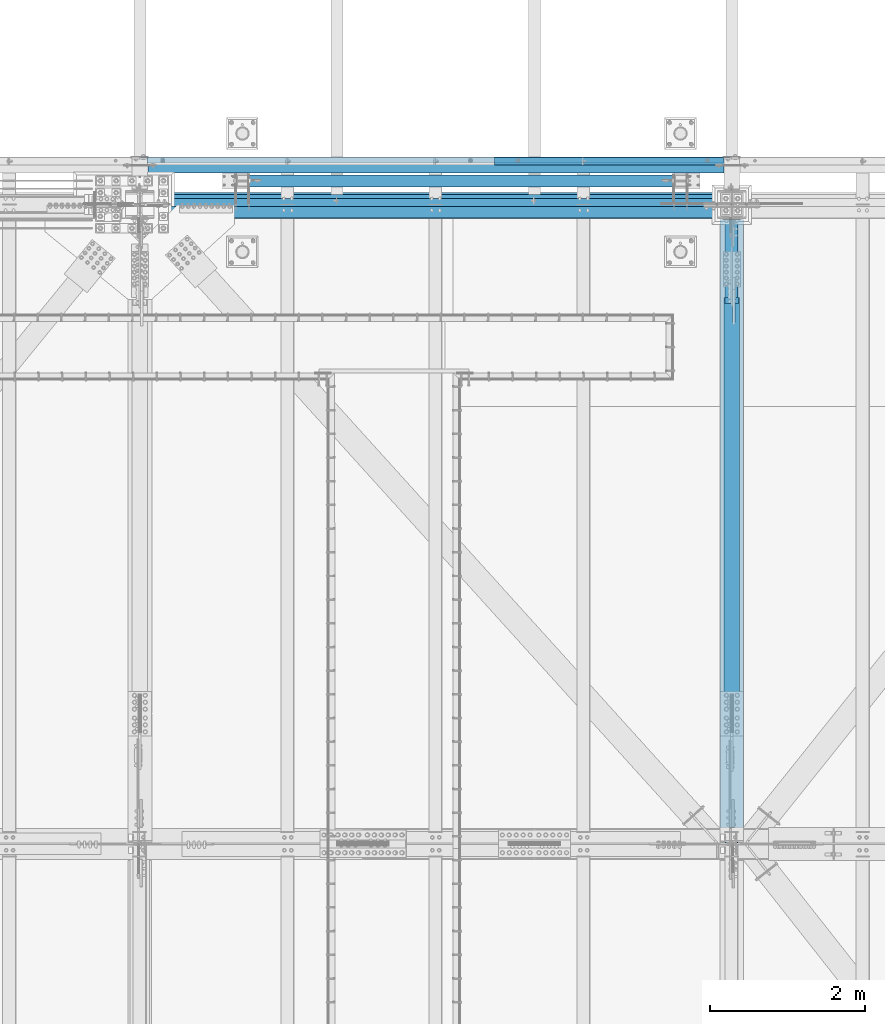
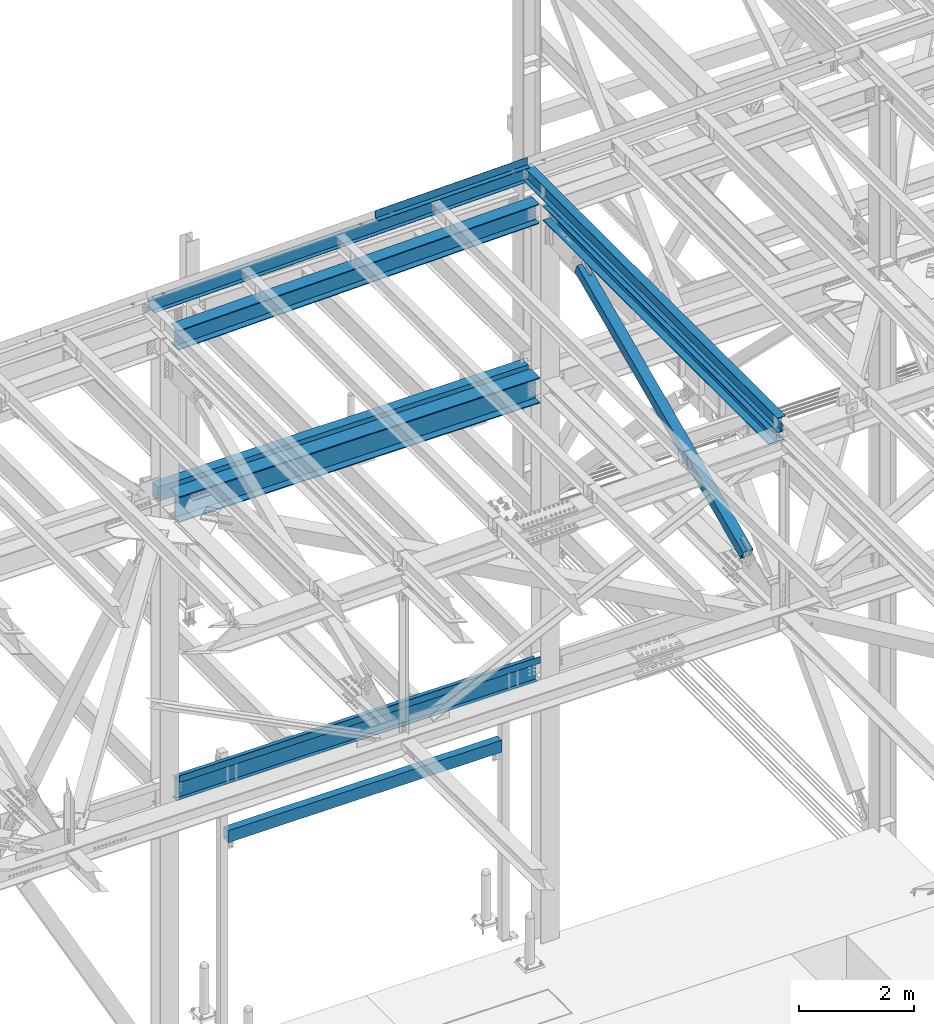
# One storey, part 1928 of 3843: 10 beams, 1 member, 9 elements without a shape of their own.
"""IFC2X3 building model written with IfcOpenShell, lengths in millimetres."""

from ifc_helpers import new_model, si_unit, frame, origin_with_axes, place, context, subcontext, project, spatial, faceted_brep, material, type_object, element, aggregate, save


model = new_model("IFC2X3")

# Units and contexts
model_context = context("Model", 3, precision=1e-05, world=origin_with_axes())
body_context = subcontext(model_context, "Body", "Model", "MODEL_VIEW")
ifc_project = project(units=[si_unit("LENGTHUNIT", "METRE", prefix="MILLI"), si_unit("AREAUNIT", "SQUARE_METRE"), si_unit("VOLUMEUNIT", "CUBIC_METRE"), si_unit("MASSUNIT", "GRAM", prefix="KILO"), si_unit("TIMEUNIT", "SECOND"), si_unit("PLANEANGLEUNIT", "RADIAN"), si_unit("SOLIDANGLEUNIT", "STERADIAN"), si_unit("THERMODYNAMICTEMPERATUREUNIT", "DEGREE_CELSIUS"), si_unit("LUMINOUSINTENSITYUNIT", "LUMEN")], contexts=[model_context])

# Site, building, storey
site_placement = place(None, origin_with_axes())
site = spatial("IfcSite", under=ifc_project, at=site_placement, CompositionType="ELEMENT")
building_placement = place(site_placement, origin_with_axes())
building = spatial("IfcBuilding", under=site, at=building_placement, Name="Undefined", CompositionType="ELEMENT")
storey_placement = place(building_placement, origin_with_axes())
storey = spatial("IfcBuildingStorey", under=building, at=storey_placement, Name="Undefined", CompositionType="ELEMENT", Elevation=0.0)

# Assembly, beam
assembly_1_placement = place(storey_placement, origin_with_axes())
assembly_1 = element("IfcElementAssembly", 1, at=assembly_1_placement, inside=storey, Name="CHANNEL", AssemblyPlace="NOTDEFINED", PredefinedType="RIGID_FRAME")
ifc_material_1 = material(Name="STEEL/A572-50")
beam_type_1 = type_object("IfcBeamType", Name="C12X20.7", PredefinedType="NOTDEFINED")
beam_1_placement = place(assembly_1_placement, frame((62633.0420977104, 92786.1999979518, 46128.444972132), z_axis=(-0.0211520980073474, 0.0, 0.999776269347241), x_axis=(0.999776270257024, 0.0, 0.0211520550054619)))
beam_1 = element("IfcBeam", 2, at=beam_1_placement, type_object=beam_type_1, material=ifc_material_1, Name="CHANNEL", ObjectType="C12X20.7", context=body_context, shape_type="Brep", body=[
    faceted_brep([(15.8752464537756, 30.1625000000058, -126.999999939733), (15.8750003662499, 38.1000000000058, -127.000000023749), (85.725000532555, 38.1000000000058, -127.000000023691), (85.725000532555, 30.1625000000058, -127.000000023691), (90.5850800505723, 38.1000000000058, -127.966729946267), (90.5850800505723, 30.1625000000058, -127.966729946267), (94.7052565187187, 38.1000000000058, -130.719743846734), (94.7052565187187, 30.1625000000058, -130.719743846734), (97.4582704191853, 38.1000000000058, -134.839920314858), (97.458270419178, 30.1625000000058, -134.674927499669), (98.4250003417692, 1.00112811196595e-06, -139.699999832876), (98.4250003417692, 38.1000000000058, -139.699999832876), (98.4250003417837, 38.1000000000058, -152.399999999638), (98.4250003417837, -38.1000000000058, -152.399999999638), (98.4250003417765, -38.1000000000058, -146.047459999652), (7523.28318920102, -38.1000000000058, 146.047460007321), (7523.28318920101, -38.1000000000058, 152.400000007307), (98.4250003414782, -38.1000000000058, 152.399999999863), (98.4250003414927, -38.1000000000058, 146.047459999871), (7523.28318920101, 38.1000000000058, 152.400000007307), (98.4250003414782, 38.1000000000058, 152.399999999863), (85.7250005323076, 30.1625000000058, 126.99999997508), (85.7250005323076, 38.1000000000058, 126.99999997508), (15.8750006201954, 38.1000000000058, 126.999999975014), (15.8752517919565, 30.1625000000058, 127.000000059044), (90.5850800503176, 30.1625000000058, 127.966729897671), (90.5850800503176, 38.1000000000058, 127.966729897671), (94.7052565184495, 30.1625000000058, 130.719743798138), (94.7052565184495, 38.1000000000058, 130.719743798138), (97.4582704189161, 30.1625000000058, 134.674927499887), (97.4582704189233, 38.1000000000058, 134.839920266269), (98.4250003414927, 1.29402906168252e-06, 139.699999784301), (98.4250003414927, 38.1000000000058, 139.699999784301), (7524.24991912362, 30.1625000000058, 134.674927507331), (7523.28318920104, 2.4073087843135e-06, 139.699999606266), (7523.28318920104, 38.1000000000058, 139.699999606266), (7524.24991912362, 38.1000000000058, 134.839920088249), (7527.00293302412, 30.1625000000058, 130.719743620124), (7527.00293302412, 38.1000000000058, 130.719743620124), (7531.12310949228, 30.1625000000058, 127.966729719657), (7531.12310949228, 38.1000000000058, 127.966729719657), (7535.98318901036, 30.1625000000058, 126.999999797081), (7535.98318901036, 38.1000000000058, 126.999999797081), (7605.83053466881, 30.1625000000058, 126.999999797132), (7605.83022600554, 38.1000000000058, 126.999999797139), (7605.83053421144, 30.1625000000058, 114.299999001392), (7605.83052590682, 30.1625000000058, -116.300000996322), (7605.83052552149, 30.1625000000058, -127.000000201639), (7605.83021685822, 38.1000000000058, -127.000000201639), (7535.98318901064, 30.1625000000058, -127.000000201682), (7535.98318901064, 38.1000000000058, -127.000000201682), (7531.12310949257, 30.1625000000058, -127.966730124273), (7531.12310949257, 38.1000000000058, -127.966730124273), (7527.00293302441, 30.1625000000058, -130.71974402474), (7527.00293302441, 38.1000000000058, -130.71974402474), (7524.24991912393, 30.1625000000058, -134.674927492233), (7524.24991912393, 38.1000000000058, -134.839920492872), (7523.28318920133, -1.12078851088881e-07, -139.700000010889), (7523.28318920133, 38.1000000000058, -139.700000010889), (7523.28318920134, -38.1000000000058, -146.047459992216), (7523.28318920134, -38.1000000000058, -152.399999992194), (7523.28318920134, 38.1000000000058, -152.399999992194), (15.8752466786536, 30.1625000000058, -116.299999310024), (15.8752515250453, 30.1625000000058, 114.300000683208)], [[[0, 1, 2, 3]], [[3, 2, 4, 5]], [[5, 4, 6, 7]], [[7, 6, 8, 9]], [[10, 11, 12, 13, 14]], [[9, 8, 11, 10]], [[15, 16, 17, 18]], [[16, 19, 20, 17]], [[21, 22, 23, 24]], [[25, 26, 22, 21]], [[27, 28, 26, 25]], [[29, 30, 28, 27]], [[31, 32, 30, 29]], [[17, 20, 32, 31, 18]], [[29, 33, 34, 15, 18, 31]], [[16, 15, 34, 35, 19]], [[33, 36, 35, 34]], [[37, 38, 36, 33]], [[39, 40, 38, 37]], [[41, 42, 40, 39]], [[43, 44, 42, 41]], [[44, 43, 45, 46, 47, 48]], [[47, 49, 50, 48]], [[51, 52, 50, 49]], [[53, 54, 52, 51]], [[55, 56, 54, 53]], [[57, 58, 56, 55]], [[59, 60, 61, 58, 57]], [[60, 59, 14, 13]], [[61, 60, 13, 12]], [[6, 4, 2, 1, 23, 22, 26, 28, 30, 32, 20, 19, 35, 36, 38, 40, 42, 44, 48, 50, 52, 54, 56, 58, 61, 12, 11, 8]], [[62, 63, 24, 23, 1, 0]], [[55, 53, 51, 49, 47, 46, 45, 43, 41, 39, 37, 33, 29, 27, 25, 21, 24, 63, 62, 0, 3, 5, 7, 9]], [[59, 57, 55, 9, 10, 14]]]),
])

assembly_2_placement = place(storey_placement, origin_with_axes())
assembly_2 = element("IfcElementAssembly", 3, at=assembly_2_placement, inside=storey, Name="BEAM", AssemblyPlace="NOTDEFINED", PredefinedType="RIGID_FRAME")
ifc_material_2 = material(Name="STEEL/A992")
beam_type_2 = type_object("IfcBeamType", Name="W12X26", PredefinedType="NOTDEFINED")
beam_2_placement = place(assembly_2_placement, frame((70253.1092623905, 83985.3859476717, 46302.7356375803), z_axis=(-0.0211520977514592, 0.00183800499970675, 0.999774579842043), x_axis=(0.0, 0.999998310110039, -0.00183841700020231)))
beam_2 = element("IfcBeam", 4, at=beam_2_placement, type_object=beam_type_2, material=ifc_material_2, Name="BEAM", ObjectType="W12X26", context=body_context, shape_type="Brep", body=[
    faceted_brep([(12.7032316026452, 82.5500000008906, -155.575000000761), (12.6857245687861, 82.550000000876, -146.050000000731), (8839.2149373373, 82.5500000014727, -146.050000029354), (8839.21493733734, 82.5500000015018, -155.575000029385), (12.6826379569102, 3.17500000042492, -146.050000000549), (8839.2149373368, 3.1750000010361, -146.050000029165), (12.1457555855741, 3.17499999961001, 146.050000000469), (8839.21493733574, 3.17500000022119, 146.049999971852), (12.14884219745, 82.550000000032, 146.050000000294), (8839.21493733625, 82.5500000006432, 146.049999971663), (12.1313351636054, 82.5500000000175, 155.575000000317), (8839.2149373362, 82.5500000006141, 155.574999971701), (12.124915010907, -82.5500000009051, 155.575000000703), (8839.21493733513, -82.5500000002939, 155.574999972079), (12.1424220447516, -82.5500000008615, 146.050000000665), (8839.21493733516, -82.5500000002503, 146.049999972041), (12.1455086566275, -3.17500000042492, 146.050000000483), (8839.21493733568, -3.17499999982829, 146.049999971867), (12.6823910279636, -3.17499999959546, -146.050000000534), (8839.21493733674, -3.17499999898428, -146.05000002915), (12.6793044160877, -82.550000000032, -146.050000000352), (8839.21493733623, -82.5499999994354, -146.050000028976), (12.6968114499323, -82.5500000000175, -155.57500000039), (8839.21493733626, -82.5499999994063, -155.575000029006)], [[[0, 1, 2, 3]], [[1, 4, 5, 2]], [[4, 6, 7, 5]], [[6, 8, 9, 7]], [[8, 10, 11, 9]], [[10, 12, 13, 11]], [[12, 14, 15, 13]], [[14, 16, 17, 15]], [[16, 18, 19, 17]], [[18, 20, 21, 19]], [[20, 22, 23, 21]], [[22, 0, 3, 23]], [[5, 7, 9, 11, 13, 15, 17, 19, 21, 23, 3, 2]], [[22, 20, 18, 16, 14, 12, 10, 8, 6, 4, 1, 0]]]),
])
aggregate(assembly_2, [beam_2])

# Beam
ifc_material_3 = material(Name="STEEL/A36")
beam_type_3 = type_object("IfcBeamType", PredefinedType="NOTDEFINED")
beam_3_placement = place(assembly_1_placement, frame((68725.1813147348, 92722.6999708297, 46412.9451497034), z_axis=(0.999776270257024, 0.0, 0.0211520550054619), x_axis=(0.0, 1.0, 0.0)))
beam_3 = element("IfcBeam", 5, at=beam_3_placement, type_object=beam_type_3, material=ifc_material_3, Name="BENT_PLATE", context=body_context, shape_type="Brep", body=[
    faceted_brep([(-5.28234522789717e-09, 1.04169885162264e-07, -1524.79400000861), (-6.66477717459202e-09, 3.17499999871507, -1521.61900009272), (95.2499987022602, 3.17500004013709, -1521.61900009349), (98.4249986312061, 1.46974343806505e-07, -1524.79400000939), (95.2499986384064, 161.925001341384, -1521.61900009353), (98.4249985660863, 161.925001342694, -1524.79400000979), (95.2499987169431, 3.17500004271278, 1524.79400000787), (95.2499986491457, 161.925001348034, 1524.79400000749), (-3.91446519643068e-09, -3.17500000128348, -1524.79400000861), (6.66477717459202e-09, -3.17499999869324, 1524.79400000864), (3.91446519643068e-09, 3.17500000129803, 1524.79400000864), (101.599998704885, -3.17499995710386, -1524.79400000941), (101.599998719568, -3.17499995451362, 1524.79400000782), (101.599998649152, 161.925001350661, 1524.79400000744), (101.599998638398, 161.925001344003, -1524.7940000098)], [[[0, 1, 2, 3]], [[3, 2, 4, 5]], [[6, 7, 4, 2]], [[8, 9, 10, 1, 0]], [[10, 6, 2, 1]], [[9, 8, 11, 12]], [[6, 10, 9, 12, 13, 7]], [[12, 11, 14, 13]], [[14, 11, 8, 0, 3, 5]], [[7, 13, 14, 5, 4]]]),
])

aggregate(assembly_1, [beam_1, beam_3])

# Assembly, beam
assembly_3_placement = place(storey_placement, origin_with_axes())
assembly_3 = element("IfcElementAssembly", 6, at=assembly_3_placement, inside=storey, Name="BEAM", AssemblyPlace="NOTDEFINED", PredefinedType="RIGID_FRAME")
beam_type_4 = type_object("IfcBeamType", Name="W21X101", PredefinedType="NOTDEFINED")
beam_4_placement = place(assembly_3_placement, frame((62636.4, 92214.7, 42197.3375), z_axis=(0.0, 0.0, 1.0), x_axis=(1.0, 0.0, 0.0)))
beam_4 = element("IfcBeam", 7, at=beam_4_placement, type_object=beam_type_4, material=ifc_material_2, Name="BEAM", ObjectType="W21X101", context=body_context, shape_type="Brep", body=[
    faceted_brep([(7423.14999999999, 6.34999999999854, -250.824999999997), (7423.14999999999, 155.575000000001, -250.824999999997), (196.850000000006, 155.575000000001, -250.824999999997), (196.850000000006, 6.34999999999854, -250.824999999997), (7423.14999999999, -155.575000000001, -271.462500000001), (7423.14999999999, -155.575000000001, -250.824999999997), (196.850000000006, -155.575000000001, -250.824999999997), (196.850000000006, -155.575000000001, -271.462500000001), (7423.14999999999, 155.575000000001, -271.462500000001), (196.850000000006, 155.575000000001, -271.462500000001), (7423.14999999999, 6.34999999999854, 250.824999999997), (7423.14999999999, 155.575000000001, 250.824999999997), (7423.14999999999, 155.575000000001, 271.462500000001), (7423.14999999999, -155.575000000001, 271.462500000001), (7423.14999999999, -155.575000000001, 250.824999999997), (7423.14999999999, -6.34999999999854, 250.824999999997), (7423.14999999999, -6.34999999999854, -250.824999999997), (193.675000000003, 6.35000000000036, 250.428), (193.675000000003, -6.35000000000036, 250.428), (193.675000000003, -6.35000000000036, 250.824999999997), (193.675000000003, 6.35000000000036, 250.824999999997), (228.60000000002, 6.35000000000036, 250.428), (228.60000000002, -6.35000000000036, 250.428), (273.984905435093, 6.35000000000036, 234.406795689014), (273.984905435093, -6.35000000000036, 234.406795689014), (278.274267898814, 6.35000000000036, 231.347328818971), (278.274267898814, -6.35000000000036, 231.347328818971), (280.281122181914, 6.35000000000036, 226.475829690324), (280.281122181914, -6.35000000000036, 226.475829690324), (279.391438807783, 6.35000000000036, 221.282812131351), (279.391438807783, -6.35000000000036, 221.282812131351), (275.877430772234, 6.35000000000036, 217.357163726287), (275.877430772234, -6.35000000000036, 217.357163726287), (270.814265581474, 6.35000000000036, 215.900000000001), (270.814265581474, -6.35000000000036, 215.900000000001), (196.85001722983, 6.34999999999854, 215.900000000001), (196.85001722983, -6.34999999999854, 215.900000000001), (196.850000000006, -6.34999999999854, -250.824999999997), (193.675000000003, 155.575000000001, 250.824999999997), (205.589601116109, 155.575000000001, 271.462500000001), (205.589601116109, -155.575000000001, 271.462500000001), (193.675000000003, -155.575000000001, 250.824999999997)], [[[0, 1, 2, 3]], [[4, 5, 6, 7]], [[8, 4, 7, 9]], [[1, 8, 9, 2]], [[0, 10, 11, 12, 13, 14, 15, 16, 5, 4, 8, 1]], [[17, 18, 19, 20]], [[21, 22, 18, 17]], [[22, 21, 23, 24]], [[24, 23, 25, 26]], [[26, 25, 27, 28]], [[28, 27, 29, 30]], [[30, 29, 31, 32]], [[32, 31, 33, 34]], [[34, 33, 35, 36]], [[16, 15, 19, 18, 22, 24, 26, 28, 30, 32, 34, 36, 37]], [[5, 16, 37, 6]], [[36, 35, 3, 2, 9, 7, 6, 37]], [[33, 31, 29, 27, 25, 23, 21, 17, 20, 10, 0, 3, 35]], [[11, 10, 20, 38]], [[12, 11, 38, 39]], [[13, 12, 39, 40]], [[14, 13, 40, 41]], [[15, 14, 41, 19]], [[40, 39, 38, 20, 19, 41]]]),
])
aggregate(assembly_3, [beam_4])

assembly_4_placement = place(storey_placement, origin_with_axes())
assembly_4 = element("IfcElementAssembly", 8, at=assembly_4_placement, inside=storey, Name="GIRT", AssemblyPlace="NOTDEFINED", PredefinedType="RIGID_FRAME")
ifc_material_4 = material()
beam_type_5 = type_object("IfcBeamType", Name="HSS12X8X3/8", PredefinedType="NOTDEFINED")
beam_5_placement = place(assembly_4_placement, frame((62636.4, 92722.7, 42214.8), z_axis=(0.0, 0.0, 1.0), x_axis=(1.0, 0.0, 0.0)))
beam_5 = element("IfcBeam", 9, at=beam_5_placement, type_object=beam_type_5, material=ifc_material_4, Name="GIRT", ObjectType="HSS12X8X3/8", context=body_context, shape_type="Brep", body=[
    faceted_brep([(103.1875, 101.600000000006, -152.400000000001), (103.1875, 101.600000000006, 152.400000000001), (7516.81249999999, 101.600000000006, 152.400000000001), (7516.81249999999, 101.600000000006, -152.400000000001), (103.1875, -101.600000000006, -152.400000000001), (7516.81249999999, -101.600000000006, -152.400000000001), (103.1875, -101.600000000006, 152.400000000001), (7516.81249999999, -101.600000000006, 152.400000000001), (103.1875, 92.0749999999971, -142.875), (103.1875, 92.0749999999971, 142.875), (103.1875, -92.0749999999971, 142.875), (103.1875, -92.0749999999971, -142.875), (7516.81249999999, -92.0749999999971, 142.875), (7516.81249999999, -92.0749999999971, -142.875), (7516.81249999999, 92.0749999999971, -142.875), (7516.81249999999, 92.0749999999971, 142.875)], [[[0, 1, 2, 3]], [[4, 0, 3, 5]], [[6, 4, 5, 7]], [[1, 6, 7, 2]], [[0, 4, 6, 1], [8, 9, 10, 11]], [[11, 10, 12, 13]], [[8, 11, 13, 14]], [[9, 8, 14, 15]], [[10, 9, 15, 12]], [[3, 2, 7, 5], [14, 13, 12, 15]]]),
])
aggregate(assembly_4, [beam_5])

# Assembly, member
assembly_5_placement = place(storey_placement, origin_with_axes())
assembly_5 = element("IfcElementAssembly", 10, at=assembly_5_placement, inside=storey, AssemblyPlace="NOTDEFINED", PredefinedType="RIGID_FRAME")
member_type = type_object("IfcMemberType", Name="HSS8X8X1/2", PredefinedType="NOTDEFINED")
member_placement = place(assembly_5_placement, frame((70256.4, 83985.1, 42262.8114064772), z_axis=(1.0, 0.0, 0.0), x_axis=(0.0, 0.912577310685205, 0.408904208858945)))
member = element("IfcMember", 11, at=member_placement, type_object=member_type, material=ifc_material_4, ObjectType="HSS8X8X1/2", context=body_context, shape_type="Brep", body=[
    faceted_brep([(1347.67603524624, -101.599999995481, 17.4624999999942), (1347.67603524629, -88.8999999954694, 17.4624999999942), (1600.08853561316, -88.8999999946036, 17.4624999999942), (1600.08853561313, -101.599999994623, 17.4624999999942), (1606.77114490473, -88.8999999945745, 16.1332463655126), (1606.77114490472, -101.599999994593, 16.1332463655126), (1612.4363875097, -88.8999999945599, 12.3478522781952), (1612.43638750968, -101.599999994579, 12.3478522781952), (1616.22178159695, -88.8999999945454, 6.68260967315291), (1616.22178159691, -101.599999994564, 6.68260967315291), (1600.08853561313, -101.599999994623, -17.4624999999942), (1600.08853561316, -88.8999999946036, -17.4624999999942), (1347.67603524629, -88.8999999954694, -17.4624999999942), (1347.67603524624, -101.599999995481, -17.4624999999942), (1606.77114490472, -101.599999994593, -16.1332463655126), (1606.77114490473, -88.8999999945745, -16.1332463655126), (1612.43638750968, -101.599999994579, -12.3478522781952), (1612.4363875097, -88.8999999945599, -12.3478522781952), (1616.22178159691, -101.599999994564, -6.68260967315291), (1616.22178159695, -88.8999999945454, -6.68260967315291), (1617.55103523137, -101.599999994557, 3.81463905796409e-07), (1617.5510352314, -88.8999999945381, 3.81463905796409e-07), (1347.6760352468, 88.900000004759, 17.4624999999942), (1347.67603524686, 101.600000004771, 17.4624999999942), (1600.08853561363, 101.600000005644, 17.4624999999942), (1600.0885356136, 88.9000000056249, 17.4624999999942), (1606.77114490523, 101.600000005658, 16.1332463655126), (1606.7711449052, 88.9000000056467, 16.1332463655126), (1612.43638751017, 101.600000005687, 12.3478522781952), (1612.43638751014, 88.9000000056612, 12.3478522781952), (1616.22178159743, 101.600000005702, 6.68260967315291), (1616.2217815974, 88.9000000056758, 6.68260967315291), (1600.0885356136, 88.9000000056249, -17.4624999999942), (1600.08853561363, 101.600000005644, -17.4624999999942), (1347.67603524686, 101.600000004771, -17.4624999999942), (1347.6760352468, 88.900000004759, -17.4624999999942), (1606.7711449052, 88.9000000056467, -16.1332463655126), (1606.77114490523, 101.600000005658, -16.1332463655126), (1612.43638751014, 88.9000000056612, -12.3478522781952), (1612.43638751017, 101.600000005687, -12.3478522781952), (1616.2217815974, 88.9000000056758, -6.68260967315291), (1616.22178159743, 101.600000005702, -6.68260967315291), (1617.55103523187, 88.9000000056758, 3.81463905796409e-07), (1617.5510352319, 101.600000005702, 3.81463905796409e-07), (1347.67603524629, -88.8999999954694, 88.8999999999942), (1347.6760352468, 88.900000004759, 88.8999999999942), (7664.35287926906, 88.9000000265069, 88.8999999999942), (7664.35287926854, -88.8999999737289, 88.8999999999942), (1347.67603524686, 101.600000004771, 101.600000000006), (7664.35287926911, 101.600000026511, 101.600000000006), (7664.35287926911, 101.600000026511, 41.2749999999942), (7411.94037889813, 101.600000025653, 41.2749999999942), (7405.25776960653, 101.600000025624, 39.9457463655126), (7399.59252700159, 101.600000025609, 36.1603522781952), (7395.80713291434, 101.600000025594, 30.4951096731529), (7394.47787927988, 101.600000025587, 23.8125003814639), (7395.80713291434, 101.600000025594, 17.1298903268471), (7399.59252700159, 101.600000025609, 11.4646477218048), (7405.25776960653, 101.600000025624, 7.6792536344874), (7411.94037889813, 101.600000025653, 6.35000000000582), (7664.35287926911, 101.600000026511, 6.35000000000582), (7664.35287926911, 101.600000026511, -101.600000000006), (1347.67603524686, 101.600000004771, -101.600000000006), (7664.35287926906, 88.9000000265069, 41.2749999999942), (7411.94037889809, 88.9000000256337, 41.2749999999942), (7405.2577696065, 88.9000000256046, 39.9457463655126), (7399.59252700154, 88.9000000255901, 36.1603522781952), (7395.8071329143, 88.9000000255755, 30.4951096731529), (7394.47787927985, 88.9000000255683, 23.8125003814639), (7395.8071329143, 88.9000000255755, 17.1298903268471), (7399.59252700154, 88.9000000255901, 11.4646477218048), (7405.2577696065, 88.9000000256046, 7.6792536344874), (7411.94037889809, 88.9000000256337, 6.35000000000582), (7664.35287926906, 88.9000000265069, 6.35000000000582), (1347.6760352468, 88.900000004759, -88.8999999999942), (1347.67603524629, -88.8999999954694, -88.8999999999942), (7664.35287926854, -88.8999999737289, -88.8999999999942), (7664.35287926906, 88.9000000265069, -88.8999999999942), (7405.25776960602, -101.599999974628, 39.9457463655126), (7405.25776960605, -88.8999999746165, 39.9457463655126), (7411.94037889763, -88.8999999745874, 41.2749999999942), (7411.94037889762, -101.599999974614, 41.2749999999942), (7399.59252700109, -101.599999974657, 36.1603522781952), (7399.59252700111, -88.8999999746384, 36.1603522781952), (7395.80713291383, -101.599999974672, 30.4951096731529), (7395.80713291385, -88.8999999746384, 30.4951096731529), (7394.47787927935, -101.599999974665, 23.8125003814639), (7394.47787927939, -88.8999999746457, 23.8125003814639), (7395.80713291383, -101.599999974672, 17.1298903268471), (7395.80713291385, -88.8999999746384, 17.1298903268471), (7399.59252700109, -101.599999974657, 11.4646477218048), (7399.59252700111, -88.8999999746384, 11.4646477218048), (7405.25776960602, -101.599999974628, 7.6792536344874), (7405.25776960605, -88.8999999746165, 7.6792536344874), (7411.94037889762, -101.599999974614, 6.35000000000582), (7411.94037889763, -88.8999999745874, 6.35000000000582), (7664.35287926851, -101.599999973741, 6.35000000000582), (7664.35287926854, -88.8999999737289, 6.35000000000582), (7664.35287926851, -101.599999973741, -101.600000000006), (1347.67603524624, -101.599999995481, -101.600000000006), (7664.35287926854, -88.8999999737289, 41.2749999999942), (7664.35287926851, -101.599999973741, 41.2749999999942), (7664.35287926851, -101.599999973741, 101.600000000006), (1347.67603524624, -101.599999995481, 101.600000000006)], [[[0, 1, 2, 3]], [[3, 2, 4, 5]], [[5, 4, 6, 7]], [[7, 6, 8, 9]], [[10, 11, 12, 13]], [[14, 15, 11, 10]], [[16, 17, 15, 14]], [[18, 19, 17, 16]], [[20, 21, 19, 18]], [[9, 8, 21, 20]], [[22, 23, 24, 25]], [[25, 24, 26, 27]], [[27, 26, 28, 29]], [[29, 28, 30, 31]], [[32, 33, 34, 35]], [[36, 37, 33, 32]], [[38, 39, 37, 36]], [[40, 41, 39, 38]], [[42, 43, 41, 40]], [[31, 30, 43, 42]], [[44, 45, 46, 47]], [[28, 26, 24, 23, 48, 49, 50, 51, 52, 53, 54, 55, 56, 57, 58, 59, 60, 61, 62, 34, 33, 37, 39, 41, 43, 30]], [[63, 64, 51, 50]], [[65, 52, 51, 64]], [[66, 53, 52, 65]], [[67, 54, 53, 66]], [[68, 55, 54, 67]], [[69, 56, 55, 68]], [[70, 57, 56, 69]], [[71, 58, 57, 70]], [[72, 59, 58, 71]], [[73, 60, 59, 72]], [[74, 75, 76, 77]], [[78, 79, 80, 81]], [[82, 83, 79, 78]], [[84, 85, 83, 82]], [[86, 87, 85, 84]], [[88, 89, 87, 86]], [[90, 91, 89, 88]], [[92, 93, 91, 90]], [[94, 95, 93, 92]], [[96, 97, 95, 94]], [[98, 61, 60, 73, 77, 76, 97, 96]], [[99, 62, 61, 98]], [[75, 74, 35, 34, 62, 99, 13, 12]], [[6, 4, 2, 1, 44, 47, 100, 80, 79, 83, 85, 87, 89, 91, 93, 95, 97, 76, 75, 12, 11, 15, 17, 19, 21, 8]], [[101, 81, 80, 100]], [[47, 46, 63, 50, 49, 102, 101, 100]], [[48, 103, 102, 49]], [[16, 14, 10, 13, 99, 98, 96, 94, 92, 90, 88, 86, 84, 82, 78, 81, 101, 102, 103, 0, 3, 5, 7, 9, 20, 18]], [[103, 48, 23, 22, 45, 44, 1, 0]], [[38, 36, 32, 35, 74, 77, 73, 72, 71, 70, 69, 68, 67, 66, 65, 64, 63, 46, 45, 22, 25, 27, 29, 31, 42, 40]]]),
])
aggregate(assembly_5, [member])

# Assembly, beam
assembly_6_placement = place(storey_placement, origin_with_axes())
assembly_6 = element("IfcElementAssembly", 12, at=assembly_6_placement, inside=storey, Name="BEAM", AssemblyPlace="NOTDEFINED", PredefinedType="RIGID_FRAME")
beam_type_6 = type_object("IfcBeamType", PredefinedType="NOTDEFINED")
beam_6_placement = place(assembly_6_placement, frame((66446.4, 92189.3, 36439.475), z_axis=(-1.0, 0.0, 0.0), x_axis=(0.0, -1.0, 0.0)))
beam_6 = element("IfcBeam", 13, at=beam_6_placement, type_object=beam_type_6, material=ifc_material_3, Name="BENT_PLATE", context=body_context, shape_type="Brep", body=[
    faceted_brep([(0.0, -3.17500000000291, -3613.14999999999), (0.0, -3.17500000000291, 3613.15), (0.0, 3.17500000000291, 3613.15), (0.0, 3.17500000000291, -3613.14999999999), (146.049993896479, 3.17500000000291, 3613.15), (146.049993896479, 3.17500000000291, -3613.14999999999), (152.399993896484, -3.17500000000291, -3613.14999999999), (152.399993896484, -3.17500000000291, 3613.15), (146.049993896479, 136.524996948239, 3613.15), (146.049993896479, 136.524996948239, -3613.14999999999), (152.399993896484, 136.524996948239, 3613.15), (152.399993896484, 136.524996948239, -3613.14999999999)], [[[0, 1, 2, 3]], [[3, 2, 4, 5]], [[1, 0, 6, 7]], [[5, 4, 8, 9]], [[4, 2, 1, 7, 10, 8]], [[7, 6, 11, 10]], [[6, 0, 3, 5, 9, 11]], [[10, 11, 9, 8]]]),
])

assembly_7_placement = place(storey_placement, origin_with_axes())
assembly_7 = element("IfcElementAssembly", 14, at=assembly_7_placement, inside=storey, Name="BEAM", AssemblyPlace="NOTDEFINED", PredefinedType="RIGID_FRAME")
beam_type_7 = type_object("IfcBeamType", Name="W16X67", PredefinedType="NOTDEFINED")
beam_7_placement = place(assembly_7_placement, frame((62640.7988429664, 92214.7, 45761.8145292208), z_axis=(-0.0211520980073474, 0.0, 0.999776269347241), x_axis=(0.999776270257024, 0.0, 0.0211520550054619)))
beam_7 = element("IfcBeam", 15, at=beam_7_placement, type_object=beam_type_7, material=ifc_material_2, Name="BEAM", ObjectType="W16X67", context=body_context, shape_type="Brep", body=[
    faceted_brep([(188.094396478875, -130.174999999999, -207.962499999492), (188.094396478875, 130.174999999999, -207.962499999492), (7416.01150275391, 130.174999999999, -207.962499992216), (7416.01150275391, -130.174999999999, -207.962499992216), (188.463847647872, -130.174999999999, -190.49999999952), (188.463847647872, -4.76250000000073, -190.49999999952), (189.242288995723, -4.76249999999709, -153.706144372947), (195.989385218127, -4.76249999999709, 165.202490022399), (196.524600426201, -4.76250000000073, 190.499999999869), (196.524600426201, -130.174999999999, 190.499999999869), (196.894051595213, -130.174999999999, 207.962499999841), (196.894051595213, 130.174999999999, 207.962499999841), (196.524600426201, 130.174999999999, 190.499999999869), (196.524600426201, 4.76250000000073, 190.499999999869), (188.463847647872, 4.76250000000073, -190.49999999952), (188.463847647872, 130.174999999999, -190.49999999952), (7416.38095392293, -130.174999999999, -190.499999992237), (7416.38095392293, -4.76250000000073, -190.499999992237), (7417.11961149971, -4.76249999999709, -155.586565880563), (7423.86670772207, -4.76249999999709, 163.32206851479), (7424.4417067012, -4.76250000000073, 190.500000007152), (7424.4417067012, -130.174999999999, 190.500000007152), (7424.81115787019, -130.174999999999, 207.962500007125), (7424.81115787019, 130.174999999999, 207.962500007125), (7424.4417067012, 130.174999999999, 190.500000007152), (7424.4417067012, 4.76250000000073, 190.500000007152), (7416.38095392293, 4.76250000000073, -190.499999992237), (7416.38095392293, 130.174999999999, -190.499999992237)], [[[0, 1, 2, 3]], [[0, 4, 5, 6, 7, 8, 9, 10, 11, 12, 13, 14, 15, 1]], [[5, 4, 16, 17]], [[8, 7, 6, 5, 17, 18, 19, 20]], [[9, 8, 20, 21]], [[10, 9, 21, 22]], [[11, 10, 22, 23]], [[12, 11, 23, 24]], [[13, 12, 24, 25]], [[14, 13, 25, 26]], [[15, 14, 26, 27]], [[1, 15, 27, 2]], [[26, 25, 24, 23, 22, 21, 20, 19, 18, 17, 16, 3, 2, 27]], [[4, 0, 3, 16]]]),
])
aggregate(assembly_7, [beam_7])

assembly_8_placement = place(storey_placement, origin_with_axes())
assembly_8 = element("IfcElementAssembly", 16, at=assembly_8_placement, inside=storey, Name="BEAM", AssemblyPlace="NOTDEFINED", PredefinedType="RIGID_FRAME")
beam_type_8 = type_object("IfcBeamType", Name="W12X65", PredefinedType="NOTDEFINED")
beam_8_placement = place(assembly_8_placement, frame((70256.4, 83985.1, 45950.2996203218), z_axis=(0.0, 0.0, 1.0), x_axis=(0.0, 1.0, 0.0)))
beam_8 = element("IfcBeam", 17, at=beam_8_placement, type_object=beam_type_8, material=ifc_material_2, Name="BEAM", ObjectType="W12X65", context=body_context, shape_type="Brep", body=[
    faceted_brep([(212.725000000006, -152.399999999994, -138.112500000003), (212.725000000006, -152.399999999994, -153.987500000003), (8039.09999999887, -152.399999999994, -153.987500000003), (8039.09999999887, -152.399999999994, -138.112500000003), (212.725000000006, -4.76249999999709, -138.112500000003), (8039.09999999887, -4.76249999999709, -138.112500000003), (212.725000000006, -4.76249999999709, 138.112500000003), (8039.09999999887, -4.76249999999709, 138.112500000003), (212.725000000006, -152.399999999994, 138.112500000003), (8039.09999999887, -152.399999999994, 138.112500000003), (212.725000000006, -152.399999999994, 153.987500000003), (8039.09999999887, -152.399999999994, 153.987500000003), (212.725000000006, 152.399999999994, 153.987500000003), (8039.09999999887, 152.399999999994, 153.987500000003), (212.725000000006, 152.399999999994, 138.112500000003), (8039.09999999887, 152.399999999994, 138.112500000003), (212.725000000006, 4.76249999999709, 138.112500000003), (8039.09999999887, 4.76249999999709, 138.112500000003), (212.725000000006, 4.76249999999709, -138.112500000003), (8039.09999999887, 4.76249999999709, -138.112500000003), (212.725000000006, 152.399999999994, -138.112500000003), (8039.09999999887, 152.399999999994, -138.112500000003), (212.725000000006, 152.399999999994, -153.987500000003), (8039.09999999887, 152.399999999994, -153.987500000003)], [[[0, 1, 2, 3]], [[4, 0, 3, 5]], [[6, 4, 5, 7]], [[8, 6, 7, 9]], [[10, 8, 9, 11]], [[12, 10, 11, 13]], [[14, 12, 13, 15]], [[16, 14, 15, 17]], [[18, 16, 17, 19]], [[20, 18, 19, 21]], [[1, 0, 4, 6, 8, 10, 12, 14, 16, 18, 20, 22]], [[1, 22, 23, 2]], [[19, 17, 15, 13, 11, 9, 7, 5, 3, 2, 23, 21]], [[22, 20, 21, 23]]]),
])
aggregate(assembly_8, [beam_8])

assembly_9_placement = place(storey_placement, origin_with_axes())
assembly_9 = element("IfcElementAssembly", 18, at=assembly_9_placement, inside=storey, Name="BEAM", AssemblyPlace="NOTDEFINED", PredefinedType="RIGID_FRAME")
beam_type_9 = type_object("IfcBeamType", Name="HSS10X6X1/4", PredefinedType="NOTDEFINED")
beam_9_placement = place(assembly_9_placement, frame((63957.2, 92519.5, 34620.2000061036), z_axis=(0.0, 0.0, 1.0), x_axis=(1.0, 0.0, 0.0)))
beam_9 = element("IfcBeam", 19, at=beam_9_placement, type_object=beam_type_9, material=ifc_material_4, Name="BEAM", ObjectType="HSS10X6X1/4", context=body_context, shape_type="Brep", body=[
    faceted_brep([(76.2000000000044, 69.8500000000058, -120.650000000001), (76.2000000000044, -69.8500000000058, -120.650000000001), (5562.60000000001, -69.8500000000058, -120.650000000001), (5562.60000000001, 69.8500000000058, -120.650000000001), (76.2000000000044, -69.8500000000058, 120.650000000001), (5562.60000000001, -69.8500000000058, 120.650000000001), (76.2000000000044, 69.8500000000058, 120.650000000001), (5562.60000000001, 69.8500000000058, 120.650000000001), (76.2000000000044, 76.1999999999971, -127.0), (76.2000000000044, 76.1999999999971, 127.0), (5562.60000000001, 76.1999999999971, 127.0), (5562.60000000001, 76.1999999999971, -127.0), (76.2000000000044, -76.1999999999971, 127.0), (5562.60000000001, -76.1999999999971, 127.0), (76.2000000000044, -76.1999999999971, -127.0), (5562.60000000001, -76.1999999999971, -127.0)], [[[0, 1, 2, 3]], [[1, 4, 5, 2]], [[4, 6, 7, 5]], [[6, 0, 3, 7]], [[8, 9, 10, 11]], [[9, 12, 13, 10]], [[12, 14, 15, 13]], [[14, 8, 11, 15]], [[13, 15, 11, 10], [5, 7, 3, 2]], [[14, 12, 9, 8], [6, 4, 1, 0]]]),
])
aggregate(assembly_9, [beam_9])

# Beam
beam_type_10 = type_object("IfcBeamType", Name="W18X40", PredefinedType="NOTDEFINED")
beam_10_placement = place(assembly_6_placement, frame((62636.4, 92214.7, 36209.2875), z_axis=(0.0, 0.0, 1.0), x_axis=(1.0, 0.0, 0.0)))
beam_10 = element("IfcBeam", 20, at=beam_10_placement, type_object=beam_type_10, material=ifc_material_2, Name="BEAM", ObjectType="W18X40", context=body_context, shape_type="Brep", body=[
    faceted_brep([(196.849999999991, -76.1999999999971, -227.012499999997), (196.849999999991, 76.1999999999971, -227.012499999997), (7423.15000000001, 76.1999999999971, -227.012499999997), (7423.15000000001, -76.1999999999971, -227.012499999997), (196.849999999999, -76.2000000000007, -214.3125), (196.849999999999, -3.96875, -214.3125), (196.849999999999, -3.96875, 214.3125), (196.849999999999, -76.2000000000007, 214.3125), (196.849999999991, -76.1999999999971, 227.012499999997), (196.849999999991, 76.1999999999971, 227.012499999997), (196.849999999999, 76.2000000000007, 214.3125), (196.849999999999, 3.96875, 214.3125), (196.849999999991, 3.96875, 196.002499999995), (196.849999999991, 3.96875, -122.977500000001), (196.849999999999, 3.96875, -214.3125), (196.849999999999, 76.2000000000007, -214.3125), (7423.15000000001, -76.1999999999971, -214.3125), (7423.15000000001, -3.96875, -214.3125), (7423.15000000001, -3.96875, 214.3125), (7423.15000000001, -76.1999999999971, 214.3125), (7423.15000000001, -76.1999999999971, 227.012499999997), (7423.15000000001, 76.1999999999971, 227.012499999997), (7423.15000000001, 76.1999999999971, 214.3125), (7423.15000000001, 3.96875, 214.3125), (7423.15000000001, 3.96875, 196.002499999995), (7423.15000000001, 3.96875, -122.977500000001), (7423.15000000001, 3.96875, -214.3125), (7423.15000000001, 76.1999999999971, -214.3125)], [[[0, 1, 2, 3]], [[0, 4, 5, 6, 7, 8, 9, 10, 11, 12, 13, 14, 15, 1]], [[5, 4, 16, 17]], [[6, 5, 17, 18]], [[7, 6, 18, 19]], [[8, 7, 19, 20]], [[9, 8, 20, 21]], [[10, 9, 21, 22]], [[11, 10, 22, 23]], [[14, 13, 12, 11, 23, 24, 25, 26]], [[15, 14, 26, 27]], [[1, 15, 27, 2]], [[26, 25, 24, 23, 22, 21, 20, 19, 18, 17, 16, 3, 2, 27]], [[4, 0, 3, 16]]]),
])

aggregate(assembly_6, [beam_6, beam_10])

save(model, "model.ifc")
